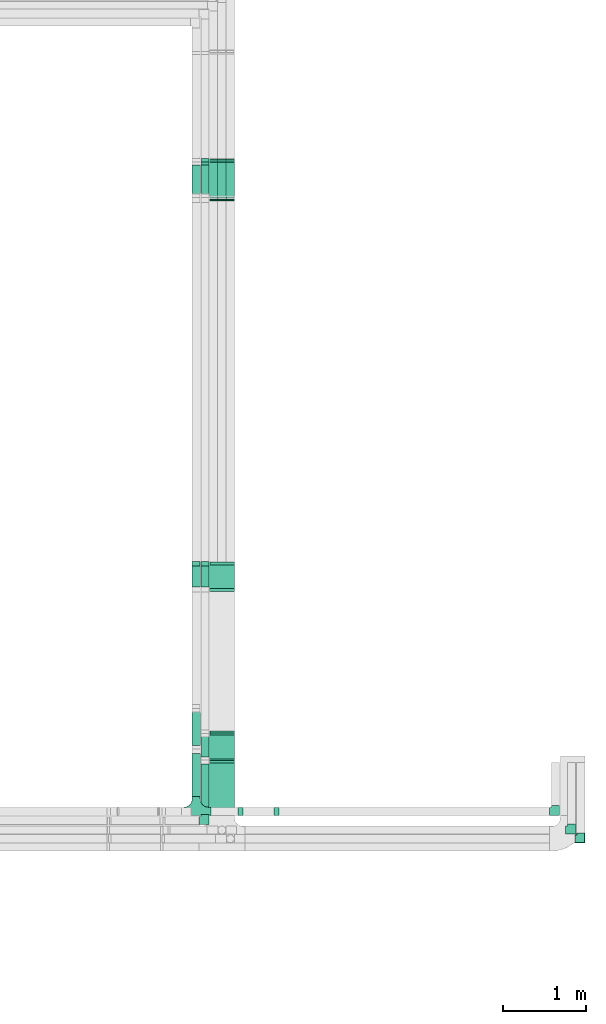
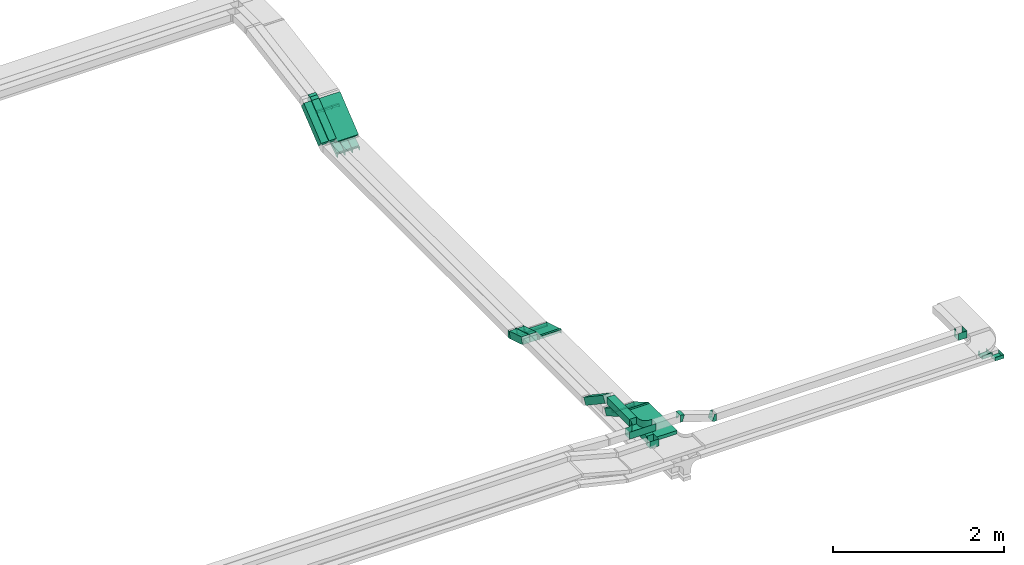
# One storey, part 11 of 14: 20 flow fittings, 15 flow segments.
"""IFC2X3 building model written with IfcOpenShell, lengths in millimetres."""

from ifc_helpers import new_model, entity, si_unit, converted_unit, derived_unit, direction, frame, frame_2d, origin, origin_2d_with_axis, place, context, subcontext, project, spatial, rectangle, extrude, faceted_brep, source, transform, mapped, material, type_object, type_shapes, element, save


model = new_model("IFC2X3")

# Units and contexts
model_context = context("Model", 3, precision=0.01, world=origin(), true_north=direction((6.12303176911189e-17, 1.0)))
body_context = subcontext(model_context, "Body", "Model", "MODEL_VIEW")
ifc_project = project(units=[si_unit("LENGTHUNIT", "METRE", prefix="MILLI"), si_unit("AREAUNIT", "SQUARE_METRE"), si_unit("VOLUMEUNIT", "CUBIC_METRE"), converted_unit("PLANEANGLEUNIT", "DEGREE", entity("IfcRatioMeasure", 0.0174532925199433), si_unit("PLANEANGLEUNIT", "RADIAN"), dimensions=[0, 0, 0, 0, 0, 0, 0]), si_unit("MASSUNIT", "GRAM", prefix="KILO"), derived_unit("MASSDENSITYUNIT", [(si_unit("MASSUNIT", "GRAM", prefix="KILO"), 1), (si_unit("LENGTHUNIT", "METRE"), -3)]), derived_unit("MOMENTOFINERTIAUNIT", [(si_unit("LENGTHUNIT", "METRE"), 4)]), si_unit("TIMEUNIT", "SECOND"), si_unit("FREQUENCYUNIT", "HERTZ"), si_unit("THERMODYNAMICTEMPERATUREUNIT", "DEGREE_CELSIUS"), derived_unit("THERMALTRANSMITTANCEUNIT", [(si_unit("MASSUNIT", "GRAM", prefix="KILO"), 1), (si_unit("THERMODYNAMICTEMPERATUREUNIT", "KELVIN"), -1), (si_unit("TIMEUNIT", "SECOND"), -3)]), derived_unit("VOLUMETRICFLOWRATEUNIT", [(si_unit("LENGTHUNIT", "METRE"), 3), (si_unit("TIMEUNIT", "SECOND"), -1)]), derived_unit("MASSFLOWRATEUNIT", [(si_unit("MASSUNIT", "GRAM", prefix="KILO"), 1), (si_unit("TIMEUNIT", "SECOND"), -1)]), derived_unit("ROTATIONALFREQUENCYUNIT", [(si_unit("TIMEUNIT", "SECOND"), -1)]), si_unit("ELECTRICCURRENTUNIT", "AMPERE"), si_unit("ELECTRICVOLTAGEUNIT", "VOLT"), si_unit("POWERUNIT", "WATT"), si_unit("FORCEUNIT", "NEWTON", prefix="KILO"), si_unit("ILLUMINANCEUNIT", "LUX"), si_unit("LUMINOUSFLUXUNIT", "LUMEN"), si_unit("LUMINOUSINTENSITYUNIT", "CANDELA"), derived_unit("USERDEFINED", [(si_unit("MASSUNIT", "GRAM", prefix="KILO"), -1), (si_unit("LENGTHUNIT", "METRE"), -2), (si_unit("TIMEUNIT", "SECOND"), 3), (si_unit("LUMINOUSFLUXUNIT", "LUMEN"), 1)]), derived_unit("LINEARVELOCITYUNIT", [(si_unit("LENGTHUNIT", "METRE"), 1), (si_unit("TIMEUNIT", "SECOND"), -1)]), si_unit("PRESSUREUNIT", "PASCAL"), derived_unit("USERDEFINED", [(si_unit("LENGTHUNIT", "METRE"), -2), (si_unit("MASSUNIT", "GRAM", prefix="KILO"), 1), (si_unit("TIMEUNIT", "SECOND"), -2)]), derived_unit("LINEARFORCEUNIT", [(si_unit("MASSUNIT", "GRAM", prefix="KILO"), 1), (si_unit("LENGTHUNIT", "METRE"), 1), (si_unit("TIMEUNIT", "SECOND"), -2), (si_unit("LENGTHUNIT", "METRE"), -1)]), derived_unit("PLANARFORCEUNIT", [(si_unit("MASSUNIT", "GRAM", prefix="KILO"), 1), (si_unit("LENGTHUNIT", "METRE"), 1), (si_unit("TIMEUNIT", "SECOND"), -2), (si_unit("LENGTHUNIT", "METRE"), -2)])], contexts=[model_context])

# Site, building, storey
site_placement = place(None, origin())
site = spatial("IfcSite", under=ifc_project, at=site_placement, CompositionType="ELEMENT")
building_placement = place(site_placement, origin())
building = spatial("IfcBuilding", under=site, at=building_placement, CompositionType="ELEMENT")
storey_placement = place(building_placement, frame((0.0, 0.0, 19800.0)))
storey = spatial("IfcBuildingStorey", under=building, at=storey_placement, Name="06", CompositionType="ELEMENT", Elevation=19800.0)

# Flow segments
cable_carrier_segment_type = type_object("IfcCableCarrierSegmentType", PredefinedType="CABLETRAYSEGMENT")
flow_segment_1_placement = place(storey_placement, frame((64391.91, 17411.15, 2720.97)))
element("IfcFlowSegment", 1, at=flow_segment_1_placement, inside=storey, type_object=cable_carrier_segment_type, context=body_context, shape_type="SweptSolid", body=[
    extrude(rectangle(XDim=49.9999999999999, YDim=558.364474472639, at=frame_2d((0.0, 0.0), x_axis=(0.0, 1.0))), frame((0.0, 232.7, 195.12), z_axis=(1.0, 0.0, 0.0), x_axis=(0.0, -0.777145961456977, -0.62932039104983)), (0.0, 0.0, 1.0), 300.000000000001),
])
flow_segment_2_placement = place(storey_placement, frame((64285.53, 17401.05, 2737.88)))
element("IfcFlowSegment", 2, at=flow_segment_2_placement, inside=storey, type_object=cable_carrier_segment_type, context=body_context, shape_type="SweptSolid", body=[
    extrude(rectangle(XDim=100.000000000002, YDim=99.9999999999916, at=origin_2d_with_axis()), frame((50.02, 31.47, 38.86), z_axis=(-3.20308930122839e-05, 0.777145960996682, 0.6293203908031), x_axis=(0.0, -0.629320391125934, 0.777145961395349)), (0.0, 0.0, 1.0), 524.408740760887),
])
flow_segment_3_placement = place(storey_placement, frame((64180.06, 17401.05, 2737.88)))
element("IfcFlowSegment", 3, at=flow_segment_3_placement, inside=storey, type_object=cable_carrier_segment_type, context=body_context, shape_type="SweptSolid", body=[
    extrude(rectangle(XDim=100.000000000001, YDim=99.9999999999946, at=origin_2d_with_axis()), frame((50.0, 31.47, 38.86), z_axis=(0.0, 0.777145961456953, 0.62932039104986), x_axis=(0.0, -0.62932039104986, 0.777145961456953)), (0.0, 0.0, 1.0), 524.410565226229),
])
flow_segment_4_placement = place(storey_placement, frame((64593.04, 17401.2, 2566.87)))
element("IfcFlowSegment", 4, at=flow_segment_4_placement, inside=storey, type_object=cable_carrier_segment_type, context=body_context, shape_type="SweptSolid", body=[
    extrude(rectangle(XDim=50.0000000000052, YDim=534.379820039847, at=frame_2d((0.0, 0.0), x_axis=(0.0, 1.0))), frame((0.0, 234.43, 171.82), z_axis=(1.0, 0.0, 0.0), x_axis=(0.0, 0.824451507844614, 0.565932603065721)), (0.0, 0.0, 1.0), 99.9999999999946),
])
for number, where in (
    (5, (64490.53, 17401.2, 2566.87)),
    (6, (64388.57, 17401.2, 2566.87)),
):
    element("IfcFlowSegment", number, at=place(storey_placement, frame(where)), inside=storey, type_object=cable_carrier_segment_type, context=body_context, shape_type="SweptSolid", body=[
        extrude(rectangle(XDim=50.0000000000052, YDim=534.379820034669, at=frame_2d((0.0, 0.0), x_axis=(0.0, 1.0))), frame((0.0, 234.43, 171.82), z_axis=(1.0, 0.0, 0.0), x_axis=(0.0, 0.824451507844611, 0.565932603065725)), (0.0, 0.0, 1.0), 99.9999999999946),
    ])
flow_segment_5_placement = place(storey_placement, frame((64393.04, 9945.0, 3000.0)))
element("IfcFlowSegment", 7, at=flow_segment_5_placement, inside=storey, type_object=cable_carrier_segment_type, context=body_context, shape_type="SweptSolid", body=[
    extrude(rectangle(XDim=637.211482764682, YDim=300.000000000001, at=origin_2d_with_axis()), frame((150.0, 318.61, 0.0), z_axis=(0.0, 0.0, 1.0), x_axis=(0.0, 1.0, 0.0)), (0.0, 0.0, 1.0), 49.9999999999973),
])
flow_segment_6_placement = place(storey_placement, frame((64393.04, 10606.54, 2813.22)))
element("IfcFlowSegment", 8, at=flow_segment_6_placement, inside=storey, type_object=cable_carrier_segment_type, context=body_context, shape_type="SweptSolid", body=[
    extrude(rectangle(XDim=49.9999999999989, YDim=360.525588832415, at=frame_2d((0.0, 0.0), x_axis=(0.0, 1.0))), frame((0.0, 168.61, 111.78), z_axis=(1.0, 0.0, 0.0), x_axis=(0.0, 0.866025403784418, -0.500000000000036)), (0.0, 0.0, 1.0), 300.000000000001),
])
flow_segment_7_placement = place(storey_placement, frame((64285.55, 10605.64, 2823.27)))
element("IfcFlowSegment", 9, at=flow_segment_7_placement, inside=storey, type_object=cable_carrier_segment_type, context=body_context, shape_type="SweptSolid", body=[
    extrude(rectangle(XDim=99.9999999999989, YDim=99.9999999999946, at=origin_2d_with_axis()), frame((50.0, 25.0, 210.16), z_axis=(0.0, 0.866025403784326, -0.500000000000195), x_axis=(0.0, 0.500000000000195, 0.866025403784326)), (0.0, 0.0, 1.0), 333.724470253517),
])
flow_segment_8_placement = place(storey_placement, frame((64285.55, 9956.0, 3000.0)))
element("IfcFlowSegment", 10, at=flow_segment_8_placement, inside=storey, type_object=cable_carrier_segment_type, context=body_context, shape_type="SweptSolid", body=[
    extrude(rectangle(XDim=612.814024398429, YDim=99.9999999999946, at=origin_2d_with_axis()), frame((50.0, 306.41, 0.0), z_axis=(0.0, 0.0, 1.0), x_axis=(0.0, 1.0, 0.0)), (0.0, 0.0, 1.0), 100.000000000003),
])
flow_segment_9_placement = place(storey_placement, frame((64180.06, 10175.0, 3146.68)))
element("IfcFlowSegment", 11, at=flow_segment_9_placement, inside=storey, type_object=cable_carrier_segment_type, context=body_context, shape_type="SweptSolid", body=[
    extrude(rectangle(XDim=523.063851606019, YDim=99.9999999999946, at=origin_2d_with_axis()), frame((50.0, 261.53, 0.0), z_axis=(0.0, 0.0, 1.0), x_axis=(0.0, 1.0, 0.0)), (0.0, 0.0, 1.0), 100.000000000003),
])
flow_segment_10_placement = place(storey_placement, frame((64180.06, 10737.84, 2829.04)))
element("IfcFlowSegment", 12, at=flow_segment_10_placement, inside=storey, type_object=cable_carrier_segment_type, context=body_context, shape_type="SweptSolid", body=[
    extrude(rectangle(XDim=99.9999999999974, YDim=99.9999999999946, at=origin_2d_with_axis()), frame((50.0, 27.84, 347.08), z_axis=(0.0, 0.830647645705059, -0.556798427336718), x_axis=(0.0, 0.556798427336718, 0.830647645705059)), (0.0, 0.0, 1.0), 548.755620607478),
])
flow_segment_11_placement = place(storey_placement, frame((64393.04, 12673.69, 2704.96)))
element("IfcFlowSegment", 13, at=flow_segment_11_placement, inside=storey, type_object=cable_carrier_segment_type, context=body_context, shape_type="SweptSolid", body=[
    extrude(rectangle(XDim=50.0000000000024, YDim=315.590748852371, at=frame_2d((0.0, 0.0), x_axis=(0.0, 1.0))), frame((0.0, 158.21, 70.04), z_axis=(1.0, 0.0, 0.0), x_axis=(0.0, 0.956304755963003, -0.292371704722843)), (0.0, 0.0, 1.0), 300.000000000001),
])
flow_segment_12_placement = place(storey_placement, frame((64285.55, 12676.65, 2708.42)))
element("IfcFlowSegment", 14, at=flow_segment_12_placement, inside=storey, type_object=cable_carrier_segment_type, context=body_context, shape_type="SweptSolid", body=[
    extrude(rectangle(XDim=100.000000000005, YDim=99.9999999999946, at=frame_2d((0.0, 0.0), x_axis=(0.0, 1.0))), frame((50.0, 14.62, 135.71), z_axis=(0.0, 0.956304755963, -0.292371704722853), x_axis=(-1.0, 0.0, 0.0)), (0.0, 0.0, 1.0), 300.639738492675),
])
flow_segment_13_placement = place(storey_placement, frame((64180.06, 12676.65, 2708.42)))
element("IfcFlowSegment", 15, at=flow_segment_13_placement, inside=storey, type_object=cable_carrier_segment_type, context=body_context, shape_type="SweptSolid", body=[
    extrude(rectangle(XDim=100.000000000005, YDim=99.9999999999946, at=frame_2d((0.0, 0.0), x_axis=(0.0, 1.0))), frame((50.0, 14.62, 135.71), z_axis=(0.0, 0.956304755963006, -0.292371704722833), x_axis=(-1.0, 0.0, 0.0)), (0.0, 0.0, 1.0), 300.63847261503),
])

# Flow fittings
ifc_material = material()
cable_carrier_fitting_type_1 = type_object("IfcCableCarrierFittingType", PredefinedType="NOTDEFINED", material=ifc_material)
shared_shape_1 = source(origin(), body_context, "Body", "Brep", [
    faceted_brep([(-17.08, -25.0, 50.0), (-17.08, 25.0, 50.0), (-17.08, 25.0, 47.46), (-17.08, -22.46, 47.46), (-17.08, -22.46, -47.46), (-17.08, 25.0, -47.46), (-17.08, 25.0, -50.0), (-17.08, -25.0, -50.0), (25.98, -15.54, 50.0), (25.98, -15.54, -50.0), (5.03, 29.86, -50.0), (5.03, 29.86, -47.46), (24.92, -13.23, -47.46), (24.92, -13.23, 47.46), (5.03, 29.86, 47.46), (5.03, 29.86, 50.0), (5.49, -25.0, 50.0), (-5.49, 25.0, 50.0), (-5.49, 25.0, 47.46), (4.93, -22.46, 47.46), (4.93, -22.46, -47.46), (-5.49, 25.0, -47.46), (-5.49, 25.0, -50.0), (5.49, -25.0, -50.0)], [[[0, 1, 2, 3, 4, 5, 6, 7]], [[8, 9, 10, 11, 12, 13, 14, 15]], [[1, 0, 16, 8, 15, 17]], [[2, 1, 17, 18]], [[3, 2, 18, 14, 13, 19]], [[4, 3, 19, 20]], [[5, 4, 20, 12, 11, 21]], [[6, 5, 21, 22]], [[7, 6, 22, 10, 9, 23]], [[0, 7, 23, 16]], [[18, 17, 15, 14]], [[20, 19, 13, 12]], [[22, 21, 11, 10]], [[16, 23, 9, 8]]]),
])
type_shapes(cable_carrier_fitting_type_1, [shared_shape_1])
for number, where, z_axis, x_axis in (
    (16, (64643.04, 17870.0, 2899.57), (1.0, 0.0, 0.0), (0.0, -0.985728987268033, -0.168340023938269)),
    (17, (64540.53, 17870.0, 2899.57), (1.0, 0.0, 0.0), (0.0, -0.985728987268033, -0.168340023938269)),
    (18, (64438.57, 17870.0, 2899.57), (1.0, 0.0, 0.0), (0.0, -0.985728987268033, -0.168340023938269)),
):
    element("IfcFlowFitting", number, at=place(storey_placement, frame(where, z_axis=z_axis, x_axis=x_axis)), inside=storey, type_object=cable_carrier_fitting_type_1, material=ifc_material, context=body_context, shape_type="MappedRepresentation", body=[
        mapped(shared_shape_1, transform((0.0, 0.0, 0.0), scale=1.0)),
    ])
cable_carrier_fitting_type_2 = type_object("IfcCableCarrierFittingType", Name="ADSK_ _ :", PredefinedType="NOTDEFINED", material=ifc_material)
shared_shape_2 = source(origin(), body_context, "Body", "Brep", [
    faceted_brep([(-70.0, 50.0, -25.0), (-70.0, -50.0, -25.0), (-70.0, -50.0, 25.0), (-70.0, -47.46, 25.0), (-70.0, -47.46, -22.46), (-70.0, 47.46, -22.46), (-70.0, 47.46, 25.0), (-70.0, 50.0, 25.0), (-50.0, 50.0, -25.0), (-50.0, 70.0, -25.0), (50.0, 70.0, -25.0), (50.0, -50.0, -25.0), (50.0, -50.0, 25.0), (50.0, 70.0, 25.0), (47.46, 70.0, 25.0), (47.46, -47.46, 25.0), (47.46, -47.46, -22.46), (47.46, 70.0, -22.46), (-47.46, 70.0, -22.46), (-47.46, 47.46, -22.46), (-47.46, 47.46, 25.0), (-47.46, 70.0, 25.0), (-50.0, 70.0, 25.0), (-50.0, 50.0, 25.0)], [[[0, 1, 2, 3, 4, 5, 6, 7]], [[1, 0, 8, 9, 10, 11]], [[2, 1, 11, 12]], [[3, 2, 12, 13, 14, 15]], [[4, 3, 15, 16]], [[5, 4, 16, 17, 18, 19]], [[6, 5, 19, 20]], [[7, 6, 20, 21, 22, 23]], [[0, 7, 23, 8]], [[9, 22, 21, 18, 17, 14, 13, 10]], [[12, 11, 10, 13]], [[16, 15, 14, 17]], [[20, 19, 18, 21]], [[8, 23, 22, 9]]]),
])
type_shapes(cable_carrier_fitting_type_2, [shared_shape_2])
for number, where, name in (
    (19, (68767.44, 9770.0, 2825.0), "ADSK_ _ :"),
    (20, (68880.58, 9665.0, 2825.0), "ADSK_ _ :"),
):
    element("IfcFlowFitting", number, at=place(storey_placement, frame(where)), inside=storey, type_object=cable_carrier_fitting_type_2, material=ifc_material, Name=name, ObjectType="ADSK_ _ :", context=body_context, shape_type="MappedRepresentation", body=[
        mapped(shared_shape_2, transform((0.0, 0.0, 0.0), scale=1.0)),
    ])
cable_carrier_fitting_type_3 = type_object("IfcCableCarrierFittingType", PredefinedType="NOTDEFINED", material=ifc_material)
shared_shape_3 = source(origin(), body_context, "Body", "Brep", [
    faceted_brep([(-22.06, 25.0, 50.0), (-22.06, 25.0, -50.0), (-22.06, -25.0, -50.0), (-22.06, -25.0, -47.46), (-22.06, 22.46, -47.46), (-22.06, 22.46, 47.46), (-22.06, -25.0, 47.46), (-22.06, -25.0, 50.0), (4.04, 33.1, 50.0), (32.34, -8.13, 50.0), (32.34, -8.13, 47.46), (5.48, 31.0, 47.46), (5.48, 31.0, -47.46), (32.34, -8.13, -47.46), (32.34, -8.13, -50.0), (4.04, 33.1, -50.0), (-7.75, 25.0, 50.0), (-7.75, 25.0, -50.0), (7.75, -25.0, -50.0), (7.75, -25.0, -47.46), (-6.97, 22.46, -47.46), (-6.97, 22.46, 47.46), (7.75, -25.0, 47.46), (7.75, -25.0, 50.0)], [[[0, 1, 2, 3, 4, 5, 6, 7]], [[8, 9, 10, 11, 12, 13, 14, 15]], [[1, 0, 16, 17]], [[2, 1, 17, 15, 14, 18]], [[3, 2, 18, 19]], [[4, 3, 19, 13, 12, 20]], [[5, 4, 20, 21]], [[6, 5, 21, 11, 10, 22]], [[7, 6, 22, 23]], [[0, 7, 23, 9, 8, 16]], [[17, 16, 8, 15]], [[19, 18, 14, 13]], [[21, 20, 12, 11]], [[23, 22, 10, 9]]]),
])
type_shapes(cable_carrier_fitting_type_3, [shared_shape_3])
for number, where, z_axis, x_axis in (
    (21, (64643.04, 17397.16, 2575.0), (-1.0, 0.0, 0.0), (0.0, -0.824451507844615, -0.565932603065719)),
    (22, (64540.53, 17397.16, 2575.0), (-1.0, 0.0, 0.0), (0.0, -0.824451507844612, -0.565932603065724)),
    (23, (64438.57, 17397.16, 2575.0), (-1.0, 0.0, 0.0), (0.0, -0.824451507844612, -0.565932603065724)),
):
    element("IfcFlowFitting", number, at=place(storey_placement, frame(where, z_axis=z_axis, x_axis=x_axis)), inside=storey, type_object=cable_carrier_fitting_type_3, material=ifc_material, context=body_context, shape_type="MappedRepresentation", body=[
        mapped(shared_shape_3, transform((0.0, 0.0, 0.0), scale=1.0)),
    ])
cable_carrier_fitting_type_4 = type_object("IfcCableCarrierFittingType", PredefinedType="NOTDEFINED", material=ifc_material)
shared_shape_4 = source(origin(), body_context, "Body", "Brep", [
    faceted_brep([(-19.74, -25.0, 150.0), (-19.74, 25.0, 150.0), (-19.74, 25.0, 147.46), (-19.74, -22.46, 147.46), (-19.74, -22.46, -147.46), (-19.74, 25.0, -147.46), (-19.74, 25.0, -150.0), (-19.74, -25.0, -150.0), (29.59, -11.78, 150.0), (29.59, -11.78, -150.0), (4.59, 31.52, -150.0), (4.59, 31.52, -147.46), (28.32, -9.58, -147.46), (28.32, -9.58, 147.46), (4.59, 31.52, 147.46), (4.59, 31.52, 150.0), (6.7, -25.0, 150.0), (-6.7, 25.0, 150.0), (-6.7, 25.0, 147.46), (6.02, -22.46, 147.46), (6.02, -22.46, -147.46), (-6.7, 25.0, -147.46), (-6.7, 25.0, -150.0), (6.7, -25.0, -150.0)], [[[0, 1, 2, 3, 4, 5, 6, 7]], [[8, 9, 10, 11, 12, 13, 14, 15]], [[1, 0, 16, 8, 15, 17]], [[2, 1, 17, 18]], [[3, 2, 18, 14, 13, 19]], [[4, 3, 19, 20]], [[5, 4, 20, 12, 11, 21]], [[6, 5, 21, 22]], [[7, 6, 22, 10, 9, 23]], [[0, 7, 23, 16]], [[18, 17, 15, 14]], [[20, 19, 13, 12]], [[22, 21, 11, 10]], [[16, 23, 9, 8]]]),
])
type_shapes(cable_carrier_fitting_type_4, [shared_shape_4])
for number, where, z_axis, x_axis in (
    (24, (64543.04, 10601.95, 3025.0), (-1.0, 0.0, 0.0), (0.0, 1.0, 0.0)),
    (25, (64543.04, 10948.36, 2825.0), (1.0, 0.0, 0.0), (0.0, 0.866025403784418, -0.500000000000036)),
):
    element("IfcFlowFitting", number, at=place(storey_placement, frame(where, z_axis=z_axis, x_axis=x_axis)), inside=storey, type_object=cable_carrier_fitting_type_4, material=ifc_material, context=body_context, shape_type="MappedRepresentation", body=[
        mapped(shared_shape_4, transform((0.0, 0.0, 0.0), scale=1.0)),
    ])
cable_carrier_fitting_type_5 = type_object("IfcCableCarrierFittingType", Name="ADSK_ _ :", PredefinedType="NOTDEFINED", material=ifc_material)
shared_shape_5 = source(origin(), body_context, "Body", "Brep", [
    faceted_brep([(-70.0, 50.0, -50.0), (-70.0, -50.0, -50.0), (-70.0, -50.0, 50.0), (-70.0, -47.46, 50.0), (-70.0, -47.46, -47.46), (-70.0, 47.46, -47.46), (-70.0, 47.46, 50.0), (-70.0, 50.0, 50.0), (-50.0, 50.0, -50.0), (-50.0, 70.0, -50.0), (50.0, 70.0, -50.0), (50.0, -50.0, -50.0), (50.0, -50.0, 50.0), (50.0, 70.0, 50.0), (47.46, 70.0, 50.0), (47.46, -47.46, 50.0), (47.46, -47.46, -47.46), (47.46, 70.0, -47.46), (-47.46, 70.0, -47.46), (-47.46, 47.46, -47.46), (-47.46, 47.46, 50.0), (-47.46, 70.0, 50.0), (-50.0, 70.0, 50.0), (-50.0, 50.0, 50.0)], [[[0, 1, 2, 3, 4, 5, 6, 7]], [[1, 0, 8, 9, 10, 11]], [[2, 1, 11, 12]], [[3, 2, 12, 13, 14, 15]], [[4, 3, 15, 16]], [[5, 4, 16, 17, 18, 19]], [[6, 5, 19, 20]], [[7, 6, 20, 21, 22, 23]], [[0, 7, 23, 8]], [[9, 22, 21, 18, 17, 14, 13, 10]], [[12, 11, 10, 13]], [[16, 15, 14, 17]], [[20, 19, 18, 21]], [[8, 23, 22, 9]]]),
])
type_shapes(cable_carrier_fitting_type_5, [shared_shape_5])
flow_fitting_1_placement = place(storey_placement, frame((68573.26, 9995.0, 3050.0)))
element("IfcFlowFitting", 26, at=flow_fitting_1_placement, inside=storey, type_object=cable_carrier_fitting_type_5, material=ifc_material, Name="ADSK_ _ :", ObjectType="ADSK_ _ :", context=body_context, shape_type="MappedRepresentation", body=[
    mapped(shared_shape_5, transform((0.0, 0.0, 0.0), scale=1.0)),
])
cable_carrier_fitting_type_6 = type_object("IfcCableCarrierFittingType", Name="ADSK_ _ :", PredefinedType="NOTDEFINED", material=ifc_material)
type_shapes(cable_carrier_fitting_type_6, [shared_shape_5])
flow_fitting_2_placement = place(storey_placement, frame((64335.55, 9886.0, 3050.0)))
element("IfcFlowFitting", 27, at=flow_fitting_2_placement, inside=storey, type_object=cable_carrier_fitting_type_6, material=ifc_material, Name="ADSK_ _ :", ObjectType="ADSK_ _ :", context=body_context, shape_type="MappedRepresentation", body=[
    mapped(shared_shape_5, transform((0.0, 0.0, 0.0), scale=1.0)),
])
cable_carrier_fitting_type_7 = type_object("IfcCableCarrierFittingType", PredefinedType="NOTDEFINED", material=ifc_material)
shared_shape_6 = source(origin(), body_context, "Body", "Brep", [
    faceted_brep([(-53.41, -124.12, 50.0), (-50.0, -150.0, 50.0), (-50.0, -180.0, 50.0), (-49.2, -180.0, 50.0), (-49.2, -150.0, 50.0), (-52.63, -123.91, 50.0), (-62.7, -99.6, 50.0), (-78.72, -78.72, 50.0), (-99.6, -62.7, 50.0), (-123.91, -52.63, 50.0), (-150.0, -49.2, 50.0), (-180.0, -49.2, 50.0), (-180.0, -50.0, 50.0), (-150.0, -50.0, 50.0), (-124.12, -53.41, 50.0), (-100.0, -63.4, 50.0), (-79.29, -79.29, 50.0), (-63.4, -100.0, 50.0), (180.0, -50.0, 50.0), (180.0, -49.2, 50.0), (150.0, -49.2, 50.0), (123.91, -52.63, 50.0), (99.6, -62.7, 50.0), (78.72, -78.72, 50.0), (62.7, -99.6, 50.0), (52.63, -123.91, 50.0), (49.2, -150.0, 50.0), (49.2, -180.0, 50.0), (50.0, -180.0, 50.0), (50.0, -150.0, 50.0), (53.41, -124.12, 50.0), (63.4, -100.0, 50.0), (79.29, -79.29, 50.0), (100.0, -63.4, 50.0), (124.12, -53.41, 50.0), (150.0, -50.0, 50.0), (180.0, 49.2, 50.0), (180.0, 50.0, 50.0), (-180.0, 50.0, 50.0), (-180.0, 49.2, 50.0), (-180.0, -50.0, -50.0), (-180.0, 50.0, -50.0), (180.0, 50.0, -50.0), (180.0, -50.0, -50.0), (150.0, -50.0, -50.0), (124.12, -53.41, -50.0), (100.0, -63.4, -50.0), (79.29, -79.29, -50.0), (63.4, -100.0, -50.0), (53.41, -124.12, -50.0), (50.0, -150.0, -50.0), (50.0, -180.0, -50.0), (-50.0, -180.0, -50.0), (-50.0, -150.0, -50.0), (-53.41, -124.12, -50.0), (-63.4, -100.0, -50.0), (-79.29, -79.29, -50.0), (-100.0, -63.4, -50.0), (-124.12, -53.41, -50.0), (-150.0, -50.0, -50.0), (-50.0, -150.0, -49.2), (49.2, -180.0, -49.2), (-49.2, -180.0, -49.2), (-49.2, -150.0, -49.2), (-150.0, -49.2, -49.2), (-180.0, -49.2, -49.2), (180.0, -49.2, -49.2), (150.0, -49.2, -49.2), (-180.0, 49.2, -49.2), (-150.0, -50.0, -49.2), (150.0, -50.0, -49.2), (180.0, 49.2, -49.2), (49.2, -150.0, -49.2), (50.0, -150.0, -49.2), (-123.91, -52.63, -49.2), (-99.6, -62.7, -49.2), (-78.72, -78.72, -49.2), (-62.7, -99.6, -49.2), (-52.63, -123.91, -49.2), (52.63, -123.91, -49.2), (62.7, -99.6, -49.2), (78.72, -78.72, -49.2), (99.6, -62.7, -49.2), (123.91, -52.63, -49.2)], [[[0, 1, 2, 3, 4, 5, 6, 7, 8, 9, 10, 11, 12, 13, 14, 15, 16, 17]], [[18, 19, 20, 21, 22, 23, 24, 25, 26, 27, 28, 29, 30, 31, 32, 33, 34, 35]], [[36, 37, 38, 39]], [[40, 41, 42, 43, 44, 45, 46, 47, 48, 49, 50, 51, 52, 53, 54, 55, 56, 57, 58, 59]], [[2, 1, 60, 53, 52]], [[3, 2, 52, 51, 28, 27, 61, 62]], [[4, 3, 62, 63]], [[11, 10, 64, 65]], [[20, 19, 66, 67]], [[39, 38, 41, 40, 12, 11, 65, 68]], [[13, 12, 40, 59, 69]], [[18, 35, 70, 44, 43]], [[19, 18, 43, 42, 37, 36, 71, 66]], [[27, 26, 72, 61]], [[29, 28, 51, 50, 73]], [[38, 37, 42, 41]], [[36, 39, 68, 71]], [[68, 65, 64, 74, 75, 76, 77, 78, 63, 62, 61, 72, 79, 80, 81, 82, 83, 67, 66, 71]], [[14, 13, 69, 59, 58]], [[15, 14, 58, 57]], [[57, 56, 16, 15]], [[17, 16, 56, 55]], [[0, 17, 55, 54]], [[1, 0, 54, 53, 60]], [[5, 78, 77, 6]], [[6, 77, 76, 7]], [[63, 78, 5, 4]], [[8, 75, 74, 9]], [[9, 74, 64, 10]], [[7, 76, 75, 8]], [[21, 83, 82, 22]], [[22, 82, 81, 23]], [[67, 83, 21, 20]], [[24, 80, 79, 25]], [[25, 79, 72, 26]], [[23, 81, 80, 24]], [[30, 29, 73, 50, 49]], [[31, 30, 49, 48]], [[32, 31, 48, 47]], [[34, 33, 46, 45]], [[34, 45, 44, 70, 35]], [[46, 33, 32, 47]]]),
])
type_shapes(cable_carrier_fitting_type_7, [shared_shape_6])
flow_fitting_3_placement = place(storey_placement, frame((64230.06, 9995.0, 3196.68), z_axis=(0.0, 0.0, 1.0), x_axis=(-1.0, 0.0, 0.0)))
element("IfcFlowFitting", 28, at=flow_fitting_3_placement, inside=storey, type_object=cable_carrier_fitting_type_7, material=ifc_material, Name="470_DKC_S5_T", context=body_context, shape_type="MappedRepresentation", body=[
    mapped(shared_shape_6, transform((0.0, 0.0, 0.0), scale=1.0)),
])
cable_carrier_fitting_type_8 = type_object("IfcCableCarrierFittingType", PredefinedType="NOTDEFINED", material=ifc_material)
shared_shape_7 = source(origin(), body_context, "Body", "Brep", [
    faceted_brep([(-21.78, -50.0, 50.0), (-21.78, 50.0, 50.0), (-21.78, 50.0, 47.46), (-21.78, -47.46, 47.46), (-21.78, -47.46, -47.46), (-21.78, 50.0, -47.46), (-21.78, 50.0, -50.0), (-21.78, -50.0, -50.0), (36.28, -40.72, 50.0), (36.28, -40.72, -50.0), (5.11, 54.3, -50.0), (5.11, 54.3, -47.46), (35.49, -38.31, -47.46), (35.49, -38.31, 47.46), (5.11, 54.3, 47.46), (5.11, 54.3, 50.0), (7.99, -50.0, 50.0), (-7.99, 50.0, 50.0), (-7.99, 50.0, 47.46), (7.59, -47.46, 47.46), (7.59, -47.46, -47.46), (-7.99, 50.0, -47.46), (-7.99, 50.0, -50.0), (7.99, -50.0, -50.0)], [[[0, 1, 2, 3, 4, 5, 6, 7]], [[8, 9, 10, 11, 12, 13, 14, 15]], [[1, 0, 16, 8, 15, 17]], [[2, 1, 17, 18]], [[3, 2, 18, 14, 13, 19]], [[4, 3, 19, 20]], [[5, 4, 20, 12, 11, 21]], [[6, 5, 21, 22]], [[7, 6, 22, 10, 9, 23]], [[0, 7, 23, 16]], [[18, 17, 15, 14]], [[20, 19, 13, 12]], [[22, 21, 11, 10]], [[16, 23, 9, 8]]]),
])
type_shapes(cable_carrier_fitting_type_8, [shared_shape_7])
for number, where, z_axis, x_axis in (
    (29, (65207.18, 9995.0, 3050.0), (0.0, 1.0, 0.0), (-1.0, 0.0, 0.0)),
    (30, (64760.06, 9995.0, 3196.68), (0.0, 1.0, 0.0), (1.0, 0.0, 0.0)),
):
    element("IfcFlowFitting", number, at=place(storey_placement, frame(where, z_axis=z_axis, x_axis=x_axis)), inside=storey, type_object=cable_carrier_fitting_type_8, material=ifc_material, context=body_context, shape_type="MappedRepresentation", body=[
        mapped(shared_shape_7, transform((0.0, 0.0, 0.0), scale=1.0)),
    ])
cable_carrier_fitting_type_9 = type_object("IfcCableCarrierFittingType", PredefinedType="NOTDEFINED", material=ifc_material)
shared_shape_8 = source(origin(), body_context, "Body", "Brep", [
    faceted_brep([(-13.22, -25.0, 150.0), (-13.22, 25.0, 150.0), (-13.22, 25.0, 147.46), (-13.22, -22.46, 147.46), (-13.22, -22.46, -147.46), (-13.22, 25.0, -147.46), (-13.22, 25.0, -150.0), (-13.22, -25.0, -150.0), (19.95, -20.04, 150.0), (19.95, -20.04, -150.0), (5.33, 27.77, -150.0), (5.33, 27.77, -147.46), (19.21, -17.61, -147.46), (19.21, -17.61, 147.46), (5.33, 27.77, 147.46), (5.33, 27.77, 150.0), (3.74, -25.0, 150.0), (-3.74, 25.0, 150.0), (-3.74, 25.0, 147.46), (3.36, -22.46, 147.46), (3.36, -22.46, -147.46), (-3.74, 25.0, -147.46), (-3.74, 25.0, -150.0), (3.74, -25.0, -150.0)], [[[0, 1, 2, 3, 4, 5, 6, 7]], [[8, 9, 10, 11, 12, 13, 14, 15]], [[1, 0, 16, 8, 15, 17]], [[2, 1, 17, 18]], [[3, 2, 18, 14, 13, 19]], [[4, 3, 19, 20]], [[5, 4, 20, 12, 11, 21]], [[6, 5, 21, 22]], [[7, 6, 22, 10, 9, 23]], [[0, 7, 23, 16]], [[18, 17, 15, 14]], [[20, 19, 13, 12]], [[22, 21, 11, 10]], [[16, 23, 9, 8]]]),
])
type_shapes(cable_carrier_fitting_type_9, [shared_shape_8])
flow_fitting_4_placement = place(storey_placement, frame((64543.04, 12668.36, 2825.0), z_axis=(-1.0, 0.0, 0.0), x_axis=(0.0, 1.0, 0.0)))
element("IfcFlowFitting", 31, at=flow_fitting_4_placement, inside=storey, type_object=cable_carrier_fitting_type_9, material=ifc_material, context=body_context, shape_type="MappedRepresentation", body=[
    mapped(shared_shape_8, transform((0.0, 0.0, 0.0), scale=1.0)),
])
cable_carrier_fitting_type_10 = type_object("IfcCableCarrierFittingType", PredefinedType="NOTDEFINED", material=ifc_material)
type_shapes(cable_carrier_fitting_type_10, [shared_shape_8])
flow_fitting_5_placement = place(storey_placement, frame((64543.04, 12995.44, 2725.0), z_axis=(0.999999620565847, 0.000254693878166535, 0.00083306613831253), x_axis=(0.0, 0.956304755963, -0.292371704722852)))
element("IfcFlowFitting", 32, at=flow_fitting_5_placement, inside=storey, type_object=cable_carrier_fitting_type_10, material=ifc_material, context=body_context, shape_type="MappedRepresentation", body=[
    mapped(shared_shape_8, transform((0.0, 0.0, 0.0), scale=1.0)),
])
cable_carrier_fitting_type_11 = type_object("IfcCableCarrierFittingType", PredefinedType="NOTDEFINED", material=ifc_material)
shared_shape_9 = source(origin(), body_context, "Body", "Brep", [
    faceted_brep([(-20.69, -50.0, 50.0), (-20.69, 50.0, 50.0), (-20.69, 50.0, 47.46), (-20.69, -47.46, 47.46), (-20.69, -47.46, -47.46), (-20.69, 50.0, -47.46), (-20.69, 50.0, -50.0), (-20.69, -50.0, -50.0), (34.41, -41.77, 50.0), (34.41, -41.77, -50.0), (5.17, 53.87, -50.0), (5.17, 53.87, -47.46), (33.66, -39.34, -47.46), (33.66, -39.34, 47.46), (5.17, 53.87, 47.46), (5.17, 53.87, 50.0), (7.47, -50.0, 50.0), (-7.47, 50.0, 50.0), (-7.47, 50.0, 47.46), (7.09, -47.46, 47.46), (7.09, -47.46, -47.46), (-7.47, 50.0, -47.46), (-7.47, 50.0, -50.0), (7.47, -50.0, -50.0)], [[[0, 1, 2, 3, 4, 5, 6, 7]], [[8, 9, 10, 11, 12, 13, 14, 15]], [[1, 0, 16, 8, 15, 17]], [[2, 1, 17, 18]], [[3, 2, 18, 14, 13, 19]], [[4, 3, 19, 20]], [[5, 4, 20, 12, 11, 21]], [[6, 5, 21, 22]], [[7, 6, 22, 10, 9, 23]], [[0, 7, 23, 16]], [[18, 17, 15, 14]], [[20, 19, 13, 12]], [[22, 21, 11, 10]], [[16, 23, 9, 8]]]),
])
type_shapes(cable_carrier_fitting_type_11, [shared_shape_9])
for number, where, z_axis, x_axis in (
    (33, (64335.55, 12998.56, 2750.19), (1.0, 0.0, 0.0), (0.0, 0.956304755963004, -0.292371704722839)),
    (34, (64230.06, 12998.56, 2750.19), (1.0, 9.64493499714813e-08, 3.15471608905215e-07), (0.0, 0.95630475596301, -0.29237170472282)),
):
    element("IfcFlowFitting", number, at=place(storey_placement, frame(where, z_axis=z_axis, x_axis=x_axis)), inside=storey, type_object=cable_carrier_fitting_type_11, material=ifc_material, context=body_context, shape_type="MappedRepresentation", body=[
        mapped(shared_shape_9, transform((0.0, 0.0, 0.0), scale=1.0)),
    ])
cable_carrier_fitting_type_12 = type_object("IfcCableCarrierFittingType", PredefinedType="NOTDEFINED", material=ifc_material)
shared_shape_10 = source(origin(), body_context, "Body", "Brep", [
    faceted_brep([(-32.46, -50.0, 50.0), (-32.46, 50.0, 50.0), (-32.46, 50.0, 47.46), (-32.46, -47.46, 47.46), (-32.46, -47.46, -47.46), (-32.46, 50.0, -47.46), (-32.46, 50.0, -50.0), (-32.46, -50.0, -50.0), (52.78, -27.71, 50.0), (52.78, -27.71, -50.0), (3.83, 59.49, -50.0), (3.83, 59.49, -47.46), (51.53, -25.5, -47.46), (51.53, -25.5, 47.46), (3.83, 59.49, 47.46), (3.83, 59.49, 50.0), (13.07, -50.0, 50.0), (-13.07, 50.0, 50.0), (-13.07, 50.0, 47.46), (12.41, -47.46, 47.46), (12.41, -47.46, -47.46), (-13.07, 50.0, -47.46), (-13.07, 50.0, -50.0), (13.07, -50.0, -50.0)], [[[0, 1, 2, 3, 4, 5, 6, 7]], [[8, 9, 10, 11, 12, 13, 14, 15]], [[1, 0, 16, 8, 15, 17]], [[2, 1, 17, 18]], [[3, 2, 18, 14, 13, 19]], [[4, 3, 19, 20]], [[5, 4, 20, 12, 11, 21]], [[6, 5, 21, 22]], [[7, 6, 22, 10, 9, 23]], [[0, 7, 23, 16]], [[18, 17, 15, 14]], [[20, 19, 13, 12]], [[22, 21, 11, 10]], [[16, 23, 9, 8]]]),
])
type_shapes(cable_carrier_fitting_type_12, [shared_shape_10])
flow_fitting_6_placement = place(storey_placement, frame((64335.53, 17865.28, 3127.18), z_axis=(0.999999997859196, -1.10151596796415e-05, 6.45001820814154e-05), x_axis=(0.0, -0.985728987268032, -0.168340023938277)))
element("IfcFlowFitting", 35, at=flow_fitting_6_placement, inside=storey, type_object=cable_carrier_fitting_type_12, material=ifc_material, context=body_context, shape_type="MappedRepresentation", body=[
    mapped(shared_shape_10, transform((0.0, 0.0, 0.0), scale=1.0)),
])

save(model, "model.ifc")
